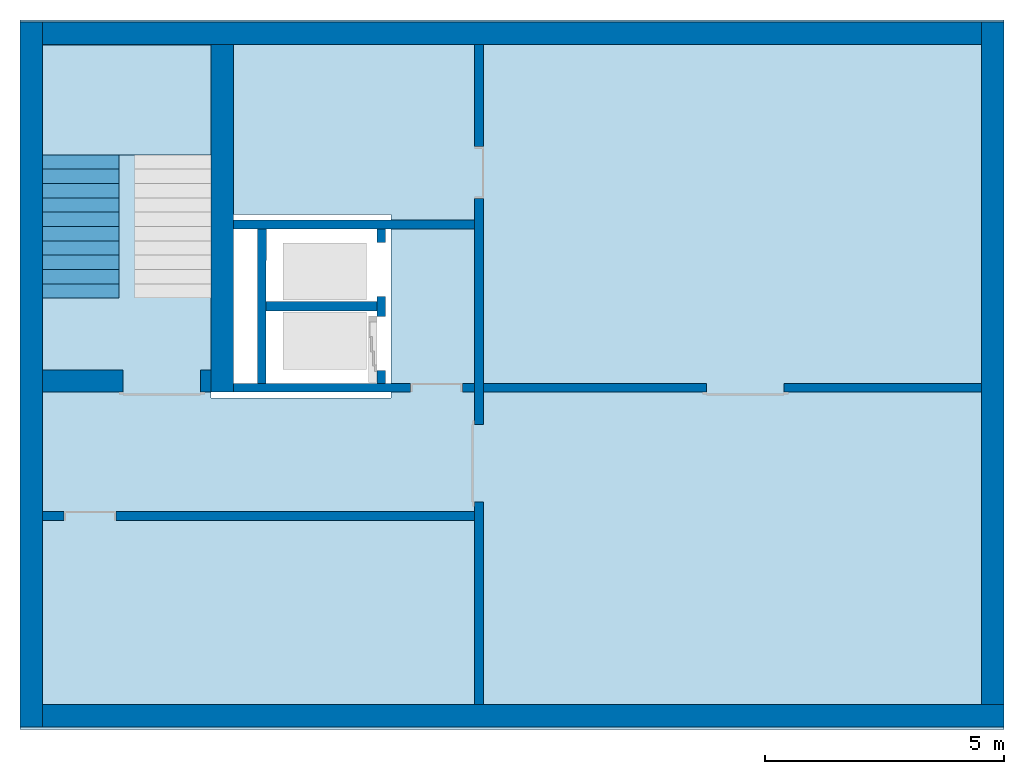
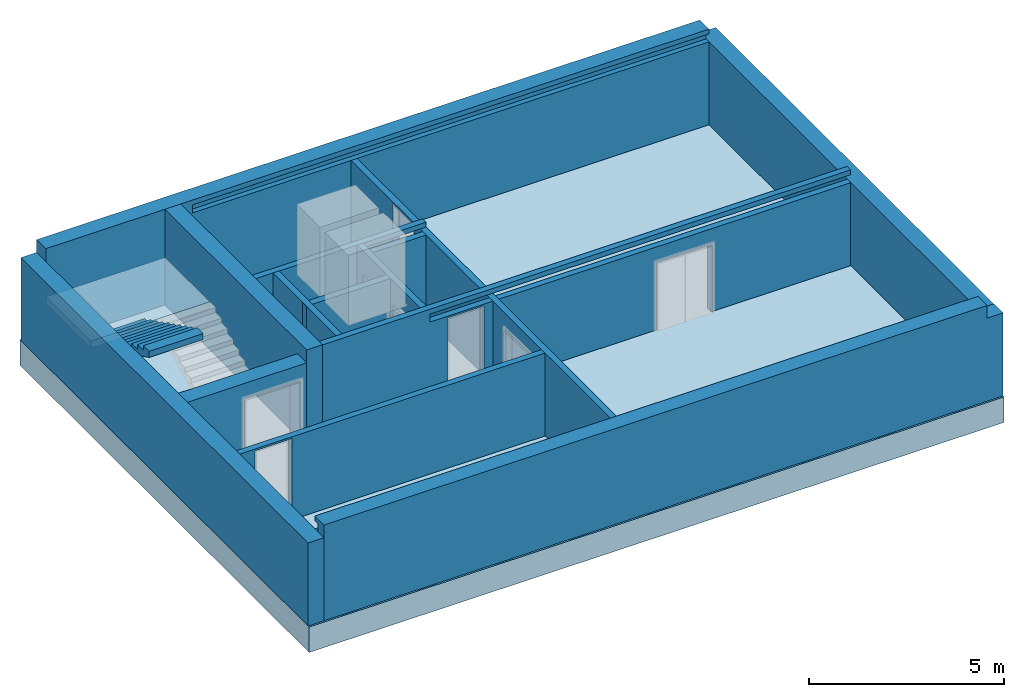
# One storey, part 1 of 5: 13 walls, 1 building element part, 1 footing, 1 slab, 8 openings, 1 element without a shape of its own.
"""IFC4 building model written with IfcOpenShell, lengths in metres."""

from ifc_helpers import new_model, entity, si_unit, converted_unit, derived_unit, direction, frame, origin_with_axes, place, context, subcontext, project, spatial, polygons, material, type_object, element, aggregate, save


model = new_model("IFC4")

# Units and contexts
model_context = context("Model", 3, precision=1e-05, world=origin_with_axes(), true_north=direction((0.0, 1.0)))
body_context = subcontext(model_context, "Body", "Model", "MODEL_VIEW")
ifc_project = project(units=[si_unit("LENGTHUNIT", "METRE"), si_unit("AREAUNIT", "SQUARE_METRE"), si_unit("VOLUMEUNIT", "CUBIC_METRE"), converted_unit("PLANEANGLEUNIT", "DEGREE", entity("IfcPlaneAngleMeasure", 0.0174532925199433), si_unit("PLANEANGLEUNIT", "RADIAN"), dimensions=[0, 0, 0, 0, 0, 0, 0]), converted_unit("TIMEUNIT", "Year", entity("IfcTimeMeasure", 31557600.0), si_unit("TIMEUNIT", "SECOND"), dimensions=[0, 0, 1, 0, 0, 0, 0]), si_unit("MASSUNIT", "GRAM", prefix="KILO"), si_unit("THERMODYNAMICTEMPERATUREUNIT", "DEGREE_CELSIUS"), si_unit("LUMINOUSINTENSITYUNIT", "LUMEN"), si_unit("ENERGYUNIT", "JOULE", prefix="MEGA"), derived_unit("THERMALCONDUCTANCEUNIT", [(si_unit("POWERUNIT", "WATT"), 1), (si_unit("LENGTHUNIT", "METRE"), -1), (si_unit("THERMODYNAMICTEMPERATUREUNIT", "KELVIN"), -1)]), derived_unit("SPECIFICHEATCAPACITYUNIT", [(si_unit("ENERGYUNIT", "JOULE"), 1), (si_unit("MASSUNIT", "GRAM", prefix="KILO"), -1), (si_unit("THERMODYNAMICTEMPERATUREUNIT", "KELVIN"), -1)]), derived_unit("MASSDENSITYUNIT", [(si_unit("MASSUNIT", "GRAM", prefix="KILO"), 1), (si_unit("VOLUMEUNIT", "CUBIC_METRE"), -1)])], contexts=[model_context])

# Site, building, storey
site_placement = place(None, origin_with_axes())
site = spatial("IfcSite", under=ifc_project, at=site_placement, CompositionType="ELEMENT")
building_placement = place(None, origin_with_axes())
building = spatial("IfcBuilding", under=site, at=building_placement, CompositionType="ELEMENT")
storey_placement = place(None, frame((0.0, 0.0, -3.0), z_axis=(0.0, 0.0, 1.0), x_axis=(1.0, 0.0, 0.0)))
storey = spatial("IfcBuildingStorey", under=building, at=storey_placement, Name="UG", CompositionType="ELEMENT", Elevation=-3.0)

# Footing
ifc_material_1 = material(Name="Stahlbeton Decke")
footing_type = type_object("IfcFootingType", Name="Stahlbeton Decke 800", PredefinedType="NOTDEFINED")
footing_placement = place(None, frame((44.584, 14.845999753475, -3.0), z_axis=(0.0, 0.0, 1.0), x_axis=(1.0, 0.0, 0.0)))
element("IfcFooting", 1, at=footing_placement, inside=storey, type_object=footing_type, material=ifc_material_1, Name="Decke-001", PredefinedType="NOTDEFINED", context=body_context, shape_type="Tessellation", body=[
    polygons([(0.0, 0.0, 0.0), (0.0, 0.0, -0.8), (-20.596, 0.0, -0.8), (-20.596, 0.0, 0.0), (0.0, -14.845999753475, 0.0), (0.0, -14.845999753475, -0.8), (-20.596, -14.845999753475, -0.8), (-12.826, -4.07099980800739, -0.8), (-16.5959999085664, -4.07099980800739, -0.8), (-16.5959999085664, -7.9109998080074, -0.8), (-12.826, -7.9109998080074, -0.8), (-20.596, -14.845999753475, 0.0), (-16.5959999085664, -7.9109998080074, 0.0), (-16.5959999085664, -4.07099980800739, 0.0), (-12.826, -4.07099980800739, 0.0), (-12.826, -7.9109998080074, 0.0)], [[[1, 2, 3, 4]], [[5, 6, 2, 1]], [[3, 2, 6, 7], [8, 9, 10, 11]], [[4, 3, 7, 12]], [[5, 1, 4, 12], [13, 14, 15, 16]], [[12, 7, 6, 5]], [[14, 9, 8, 15]], [[13, 10, 9, 14]], [[16, 11, 10, 13]], [[15, 8, 11, 16]]], closed=True),
])

# Slab
ifc_material_2 = material(Name="Stahlbeton")
slab_type = type_object("IfcSlabType", Name="Stahlbeton 220", PredefinedType="LANDING")
slab_placement = place(None, frame((24.458, 12.0249999454676, -1.5), z_axis=(0.0, 0.0, 1.0), x_axis=(1.0, 0.0, 0.0)))
element("IfcSlab", 2, at=slab_placement, inside=storey, type_object=slab_type, material=ifc_material_2, Name="Decke-002", context=body_context, shape_type="Tessellation", body=[
    polygons([(0.0, 0.0, 0.0), (0.0, 0.0, -0.22), (3.53, 0.0, -0.22), (3.53, 0.0, 0.0), (0.0, 2.30099994546756, 0.0), (0.0, 2.30099994546756, -0.22), (3.53, 2.30099994546756, -0.22), (3.53, 2.30099994546756, 0.0)], [[[1, 2, 3, 4]], [[5, 6, 2, 1]], [[3, 2, 6, 7]], [[4, 3, 7, 8]], [[5, 1, 4, 8]], [[8, 7, 6, 5]]], closed=True),
])

# Wall
wall_type_1 = type_object("IfcWallType", Name="Stahlbeton 470", PredefinedType="NOTDEFINED")
wall_1_placement = place(None, frame((24.458, 14.3318657372406, -3.0), z_axis=(0.0, 0.0, 1.0), x_axis=(0.0, -1.0, 0.0)))
element("IfcWall", 3, at=wall_1_placement, inside=storey, type_object=wall_type_1, material=ifc_material_2, Name="Wand-001", PredefinedType="NOTDEFINED", context=body_context, shape_type="Tessellation", body=[
    polygons([(14.2818657372405, -0.469999999999999, 2.6), (14.2818657372405, 0.0, 2.6), (-0.470000000000001, 0.0, 2.6), (-0.469999999999999, -0.469999999999999, 2.6), (14.2818657372405, -0.469999999999999, 0.0), (14.2818657372405, 0.0, 0.0), (-0.470000000000001, 0.0, 0.0), (-0.469999999999999, -0.469999999999999, 0.0)], [[[1, 2, 3, 4]], [[2, 1, 5, 6]], [[2, 6, 7, 3]], [[8, 4, 3, 7]], [[5, 1, 4, 8]], [[6, 5, 8, 7]]], closed=True),
])

# Wall, opening
wall_2_placement = place(None, frame((27.988, 7.05499994546755, -3.0), z_axis=(0.0, 0.0, 1.0), x_axis=(-1.0, 0.0, 0.0)))
wall_2 = element("IfcWall", 4, at=wall_2_placement, inside=storey, type_object=wall_type_1, material=ifc_material_2, Name="Wand-001", PredefinedType="NOTDEFINED", context=body_context, shape_type="Tessellation", body=[
    polygons([(1.84, -0.470000000000001, 2.11), (1.84, -0.47, 0.0), (3.53, -0.470000000000001, 0.0), (3.53, -0.47, 2.6), (0.0, -0.47, 2.6), (0.0, -0.47, 0.0), (0.219999999999999, -0.47, 0.0), (0.219999999999999, -0.470000000000001, 2.11), (1.84, 0.0, 2.11), (1.84, 0.0, 0.0), (3.53, 0.0, 0.0), (3.53, 0.0, 2.6), (0.0, 0.0, 2.6), (0.0, 0.0, 0.0), (0.219999999999999, 0.0, 0.0), (0.219999999999999, 0.0, 2.11)], [[[1, 2, 3, 4, 5, 6, 7, 8]], [[2, 1, 9, 10]], [[2, 10, 11, 3]], [[4, 3, 11, 12]], [[12, 13, 5, 4]], [[5, 13, 14, 6]], [[15, 7, 6, 14]], [[8, 7, 15, 16]], [[1, 8, 16, 9]], [[16, 15, 14, 13, 12, 11, 10, 9]]], closed=True),
])
opening_1_placement = place(None, frame((26.958, 7.05499994546755, -3.0), z_axis=(0.0, 0.0, 1.0), x_axis=(-1.0, 0.0, 0.0)))
element("IfcOpeningElement", 5, at=opening_1_placement, cuts=wall_2, context=body_context, identifier="Reference", shape_type="Tessellation", body=[
    polygons([(-0.809999999999999, -0.471, 2.11), (-0.809999999999999, -0.471, 0.0), (0.809999999999999, -0.471, 0.0), (0.809999999999999, -0.471, 2.11), (-0.809999999999999, 0.00100000000000033, 2.11), (-0.809999999999999, 0.00100000000000033, 0.0), (0.809999999999999, 0.00100000000000033, 0.0), (0.809999999999999, 0.00100000000000033, 2.11)], [[[1, 2, 3, 4]], [[5, 6, 2, 1]], [[6, 7, 3, 2]], [[7, 8, 4, 3]], [[8, 5, 1, 4]], [[7, 6, 5, 8]]], closed=True),
])

# Walls
wall_3_placement = place(None, frame((27.988, 14.3318657372406, -3.0), z_axis=(0.0, 0.0, 1.0), x_axis=(0.0, -1.0, 0.0)))
element("IfcWall", 6, at=wall_3_placement, inside=storey, type_object=wall_type_1, material=ifc_material_2, Name="Wand-003", PredefinedType="NOTDEFINED", context=body_context, shape_type="Tessellation", body=[
    polygons([(7.276865791773, 0.469999999999999, 3.0), (7.276865791773, 0.0, 3.0), (7.27686579177299, 0.0, 2.6), (7.27686579177299, 0.469999999999999, 2.6), (0.0, 0.469999999999999, 3.0), (0.0, 0.0, 3.0), (0.0, 0.0, 0.0), (7.27686579177299, 0.0, 0.0), (7.27686579177299, 0.469999999999999, 0.0), (0.0, 0.469999999999999, 0.0)], [[[1, 2, 3, 4]], [[5, 6, 2, 1]], [[6, 7, 8, 3, 2]], [[3, 8, 9, 4]], [[5, 1, 4, 9, 10]], [[6, 5, 10, 7]], [[7, 10, 9, 8]]], closed=True),
])
wall_4_placement = place(None, frame((44.114, 0.52, -3.0), z_axis=(0.0, 0.0, 1.0), x_axis=(0.0, 1.0, 0.0)))
element("IfcWall", 7, at=wall_4_placement, inside=storey, type_object=wall_type_1, material=ifc_material_2, Name="Wand-003", PredefinedType="NOTDEFINED", context=body_context, shape_type="Tessellation", body=[
    polygons([(14.2818657372405, -0.469999999999999, 2.6), (14.2818657372405, 0.0, 2.6), (0.0, 0.0, 2.6), (0.0, -0.469999999999999, 2.6), (14.2818657372405, -0.469999999999999, 0.0), (14.2818657372405, 0.0, 0.0), (0.0, 0.0, 0.0), (0.0, -0.469999999999999, 0.0)], [[[1, 2, 3, 4]], [[2, 1, 5, 6]], [[2, 6, 7, 3]], [[8, 4, 3, 7]], [[5, 1, 4, 8]], [[6, 5, 8, 7]]], closed=True),
])
wall_5_placement = place(None, frame((44.114, 14.3318657372406, -3.0), z_axis=(0.0, 0.0, 1.0), x_axis=(-1.0, 0.0, 0.0)))
element("IfcWall", 8, at=wall_5_placement, inside=storey, type_object=wall_type_1, material=ifc_material_2, Name="Wand-004", PredefinedType="NOTDEFINED", context=body_context, shape_type="Tessellation", body=[
    polygons([(0.0, 0.0, 2.85), (0.0, -0.151134016234401, 2.85), (0.0, -0.151134016234401, 2.6), (0.0, -0.470000000000001, 2.6), (0.0, -0.470000000000001, 3.0), (0.0, 0.0, 3.0), (15.306, -0.151134016234401, 2.85), (15.306, 0.0, 2.85), (15.306, -0.151134016234401, 2.6), (0.0, 0.0, 2.6), (0.0, 0.0, 0.0), (0.0, -0.470000000000001, 0.0), (19.656, -0.470000000000002, 3.0), (19.656, -0.470000000000001, 0.0), (19.656, -0.470000000000001, 2.6), (19.656, -0.470000000000002, 2.85), (19.656, 0.0, 3.0), (15.306, 0.0, 2.6), (19.656, 0.0, 2.85), (19.656, 0.0, 2.6), (19.656, 0.0, 0.0)], [[[1, 2, 3, 4, 5, 6]], [[7, 2, 1, 8]], [[9, 3, 2, 7]], [[4, 3, 10, 11, 12]], [[13, 5, 4, 12, 14, 15, 16]], [[6, 5, 13, 17]], [[18, 8, 1, 6, 17, 19, 20, 21, 11, 10]], [[7, 8, 18, 9]], [[18, 10, 3, 9]], [[21, 14, 12, 11]], [[14, 21, 20, 15]], [[19, 16, 15, 20]], [[16, 19, 17, 13]]], closed=True),
])
wall_6_placement = place(None, frame((24.458, 0.52, -3.0), z_axis=(0.0, 0.0, 1.0), x_axis=(1.0, 0.0, 0.0)))
element("IfcWall", 9, at=wall_6_placement, inside=storey, type_object=wall_type_1, material=ifc_material_2, Name="Wand-002", PredefinedType="NOTDEFINED", context=body_context, shape_type="Tessellation", body=[
    polygons([(19.656, -0.469999999999999, 2.6), (19.656, -0.156999999999999, 2.6), (19.656, -0.156999999999999, 2.85), (19.656, 0.0, 2.85), (19.656, 0.0, 3.0), (19.656, -0.469999999999999, 3.0), (20.126, 0.0, 2.6), (19.656, 0.0, 2.6), (20.126, -0.469999999999999, 2.6), (0.0, -0.156999999999999, 2.85), (0.0, -0.156999999999999, 2.6), (0.0, 0.0, 2.85), (0.0, 0.0, 3.0), (0.0, -0.47, 3.0), (0.0, -0.47, 2.6), (0.0, -0.47, 0.0), (20.126, -0.469999999999999, 0.0), (0.0, 0.0, 0.0), (0.0, 0.0, 2.6), (20.126, 0.0, 0.0)], [[[1, 2, 3, 4, 5, 6]], [[7, 8, 2, 1, 9]], [[10, 3, 2, 11]], [[10, 12, 4, 3]], [[5, 4, 12, 13]], [[5, 13, 14, 6]], [[6, 14, 15, 16, 17, 9, 1]], [[18, 19, 8, 7, 20]], [[11, 2, 8, 19]], [[9, 17, 20, 7]], [[12, 10, 11, 15, 14, 13]], [[15, 11, 19, 18, 16]], [[20, 17, 16, 18]]], closed=True),
])

# Wall, openings
wall_type_2 = type_object("IfcWallType", Name="Stahlbeton 180", PredefinedType="NOTDEFINED")
wall_7_placement = place(None, frame((31.638, 7.05499994546755, -3.0), z_axis=(0.0, 0.0, 1.0), x_axis=(0.0, 1.0, 0.0)))
wall_7 = element("IfcWall", 10, at=wall_7_placement, inside=storey, type_object=wall_type_2, material=ifc_material_2, Name="Wand-002", PredefinedType="NOTDEFINED", context=body_context, shape_type="Tessellation", body=[
    polygons([(2.0, 0.0, 0.0), (2.0, 0.0, 2.25), (3.13, 0.0, 2.25), (3.13, 0.0, 0.0), (3.42, 0.0, 0.0), (3.42, 0.0, 3.0), (0.179999999999999, 0.0, 3.0), (0.179999999999999, 0.0, 0.0), (0.450000000000002, 0.0, 0.0), (0.450000000000002, 0.0, 2.25), (1.58, 0.0, 2.25), (1.58, 0.0, 0.0), (2.0, 0.179999999999996, 0.0), (2.0, 0.179999999999996, 2.25), (3.13, 0.179999999999996, 2.25), (3.13, 0.179999999999996, 0.0), (3.42, 0.179999999999996, 0.0), (3.42, 0.179999999999996, 3.0), (0.179999999999999, 0.18, 3.0), (0.179999999999999, 0.18, 0.0), (0.450000000000002, 0.18, 0.0), (0.450000000000002, 0.18, 2.25), (1.58, 0.18, 2.25), (1.58, 0.18, 0.0)], [[[1, 2, 3, 4, 5, 6, 7, 8, 9, 10, 11, 12]], [[2, 1, 13, 14]], [[3, 2, 14, 15]], [[4, 3, 15, 16]], [[4, 16, 17, 5]], [[18, 6, 5, 17]], [[19, 7, 6, 18]], [[8, 7, 19, 20]], [[9, 8, 20, 21]], [[9, 21, 22, 10]], [[10, 22, 23, 11]], [[11, 23, 24, 12]], [[13, 1, 12, 24]], [[14, 13, 24, 23, 22, 21, 20, 19, 18, 17, 16, 15]]], closed=True),
])
opening_2_placement = place(wall_7_placement, frame((2.565, 0.0, 0.0), z_axis=(0.0, 0.0, 1.0), x_axis=(1.0, 0.0, 0.0)))
element("IfcOpeningElement", 11, at=opening_2_placement, cuts=wall_7, context=body_context, identifier="Reference", shape_type="Tessellation", body=[
    polygons([(-0.565, -0.00100000000000478, 2.25), (-0.565, -0.00100000000000478, 0.0), (0.565, -0.00100000000000478, 0.0), (0.565, -0.00100000000000478, 2.25), (-0.564999999999998, 0.181000000000001, 2.25), (-0.564999999999998, 0.181000000000001, 0.0), (0.565000000000001, 0.181000000000001, 0.0), (0.565000000000001, 0.181000000000001, 2.25)], [[[1, 2, 3, 4]], [[5, 6, 2, 1]], [[6, 7, 3, 2]], [[7, 8, 4, 3]], [[8, 5, 1, 4]], [[7, 6, 5, 8]]], closed=True),
])
opening_3_placement = place(wall_7_placement, frame((1.015, 0.0, 0.0), z_axis=(0.0, 0.0, 1.0), x_axis=(1.0, 0.0, 0.0)))
element("IfcOpeningElement", 12, at=opening_3_placement, cuts=wall_7, context=body_context, identifier="Reference", shape_type="Tessellation", body=[
    polygons([(-0.565, -0.00100000000000122, 2.25), (-0.565, -0.00100000000000122, 0.0), (0.565, -0.00100000000000122, 0.0), (0.565, -0.00100000000000122, 2.25), (-0.565, 0.181000000000004, 2.25), (-0.565, 0.181000000000004, 0.0), (0.565000000000001, 0.181000000000004, 0.0), (0.565000000000001, 0.181000000000004, 2.25)], [[[1, 2, 3, 4]], [[5, 6, 2, 1]], [[6, 7, 3, 2]], [[7, 8, 4, 3]], [[8, 5, 1, 4]], [[7, 6, 5, 8]]], closed=True),
])

# Wall, opening
wall_8_placement = place(None, frame((33.505, 4.55499994546755, -3.0), z_axis=(0.0, 0.0, 1.0), x_axis=(-1.0, 0.0, 0.0)))
wall_8 = element("IfcWall", 13, at=wall_8_placement, inside=storey, type_object=wall_type_2, material=ifc_material_2, Name="Wand-003", PredefinedType="NOTDEFINED", context=body_context, shape_type="Tessellation", body=[
    polygons([(8.59699999999999, 0.0, 2.545), (8.59699999999999, 0.0, 0.0), (9.047, 0.0, 0.0), (9.047, 0.0, 2.6), (0.0, 0.0, 2.6), (0.0, 0.0, 0.0), (7.507, 0.0, 0.0), (7.507, 0.0, 2.545), (8.59699999999999, 0.18, 2.545), (8.59699999999999, 0.18, 0.0), (9.047, 0.18, 0.0), (9.047, 0.18, 2.6), (0.0, 0.180000000000001, 2.6), (0.0, 0.18, 0.0), (7.507, 0.18, 0.0), (7.507, 0.18, 2.545)], [[[1, 2, 3, 4, 5, 6, 7, 8]], [[2, 1, 9, 10]], [[2, 10, 11, 3]], [[11, 12, 4, 3]], [[12, 13, 5, 4]], [[14, 6, 5, 13]], [[15, 7, 6, 14]], [[8, 7, 15, 16]], [[1, 8, 16, 9]], [[16, 15, 14, 13, 12, 11, 10, 9]]], closed=True),
])
opening_4_placement = place(None, frame((25.453, 4.55499994546755, -3.0), z_axis=(0.0, 0.0, 1.0), x_axis=(-1.0, 0.0, 0.0)))
element("IfcOpeningElement", 14, at=opening_4_placement, cuts=wall_8, context=body_context, identifier="Reference", shape_type="Tessellation", body=[
    polygons([(-0.544999999999998, -0.00100000000000033, 2.545), (-0.544999999999998, -0.00100000000000033, 0.0), (0.544999999999998, -0.00100000000000033, 0.0), (0.544999999999998, -0.00100000000000033, 2.545), (-0.544999999999998, 0.181, 2.545), (-0.544999999999998, 0.181, 0.0), (0.544999999999998, 0.181, 0.0), (0.544999999999998, 0.181, 2.545)], [[[1, 2, 3, 4]], [[5, 6, 2, 1]], [[6, 7, 3, 2]], [[7, 8, 4, 3]], [[8, 5, 1, 4]], [[7, 6, 5, 8]]], closed=True),
])

# Walls
wall_9_placement = place(None, frame((29.1377045594425, 7.05499994546755, -3.0), z_axis=(0.0, 0.0, 1.0), x_axis=(0.00164133421967425, 0.999998653010083, 0.0)))
element("IfcWall", 15, at=wall_9_placement, inside=storey, type_object=wall_type_2, material=ifc_material_2, Name="Wand-001", PredefinedType="NOTDEFINED", context=body_context, shape_type="Tessellation", body=[
    polygons([(0.179704801901014, 0.18, 0.0), (3.41970916615423, 0.180000000000007, 0.0), (3.42000460671172, 0.0, 0.0), (0.180000242458512, 0.0, 0.0), (0.179704801901014, 0.18, 3.0), (3.41970916615423, 0.180000000000007, 3.0), (3.42000460671172, 0.0, 3.0), (0.180000242458512, 0.0, 3.0)], [[[1, 2, 3, 4]], [[5, 6, 2, 1]], [[7, 3, 2, 6]], [[4, 3, 7, 8]], [[8, 5, 1, 4]], [[8, 7, 6, 5]]], closed=True),
])
wall_10_placement = place(None, frame((33.505, 10.6549999454676, -3.0), z_axis=(0.0, 0.0, 1.0), x_axis=(-1.0, 0.0, 0.0)))
element("IfcWall", 16, at=wall_10_placement, inside=storey, type_object=wall_type_2, material=ifc_material_2, Name="Wand-003", PredefinedType="NOTDEFINED", context=body_context, shape_type="Tessellation", body=[
    polygons([(0.0, 0.18, 3.0), (0.0, 0.180000000000001, 2.85), (0.0, 0.0, 2.85), (0.0, 0.0, 3.0), (1.8669999709129, 0.18, 2.6), (1.8669999709129, 0.18, 2.85), (5.04699999999999, 0.18, 3.0), (5.04699999999999, 0.18, 0.0), (0.0, 0.18, 0.0), (0.0, 0.180000000000003, 2.6), (1.8669999709129, -8.86263311627999e-08, 2.85), (1.8669999709129, -8.86263311627999e-08, 2.6), (0.0, 0.0, 2.6), (0.0, 0.0, 0.0), (5.04699999999999, 0.0, 0.0), (5.04699999999999, 0.0, 3.0)], [[[1, 2, 3, 4]], [[5, 6, 2, 1, 7, 8, 9, 10]], [[6, 11, 3, 2]], [[11, 12, 13, 14, 15, 16, 4, 3]], [[4, 16, 7, 1]], [[5, 12, 11, 6]], [[8, 7, 16, 15]], [[8, 15, 14, 9]], [[14, 13, 10, 9]], [[5, 10, 13, 12]]], closed=True),
])

# Wall, openings
wall_11_placement = place(None, frame((33.505, 14.3318657372406, -3.0), z_axis=(0.0, 0.0, 1.0), x_axis=(0.0, -1.0, 0.0)))
wall_11 = element("IfcWall", 17, at=wall_11_placement, inside=storey, type_object=wall_type_2, material=ifc_material_2, Name="Wand-001", PredefinedType="NOTDEFINED", context=body_context, shape_type="Tessellation", body=[
    polygons([(3.22686579177299, 0.18, 0.0), (3.22686579177299, 0.18, 2.545), (2.13686579177299, 0.18, 2.545), (2.13686579177299, 0.18, 0.0), (0.0, 0.18, 0.0), (0.0, 0.18, 2.6), (13.8118657372406, 0.18, 2.6), (13.8118657372406, 0.18, 0.0), (9.57686579177299, 0.18, 0.0), (9.57686579177299, 0.18, 2.11), (7.95686579177299, 0.18, 2.11), (7.95686579177299, 0.18, 0.0), (3.22686579177299, 0.0, 0.0), (3.22686579177299, 0.0, 2.545), (2.13686579177299, 0.0, 2.545), (2.13686579177299, 0.0, 0.0), (0.0, 0.0, 0.0), (0.0, 0.0, 2.6), (13.8118657372406, 0.0, 2.6), (13.8118657372406, 0.0, 0.0), (9.57686579177299, 0.0, 0.0), (9.57686579177299, 0.0, 2.11), (7.95686579177299, 0.0, 2.11), (7.95686579177299, 0.0, 0.0)], [[[1, 2, 3, 4, 5, 6, 7, 8, 9, 10, 11, 12]], [[2, 1, 13, 14]], [[3, 2, 14, 15]], [[4, 3, 15, 16]], [[4, 16, 17, 5]], [[17, 18, 6, 5]], [[6, 18, 19, 7]], [[7, 19, 20, 8]], [[9, 8, 20, 21]], [[9, 21, 22, 10]], [[10, 22, 23, 11]], [[11, 23, 24, 12]], [[13, 1, 12, 24]], [[14, 13, 24, 23, 22, 21, 20, 19, 18, 17, 16, 15]]], closed=True),
])
opening_5_placement = place(None, frame((33.505, 11.6499999454676, -3.0), z_axis=(0.0, 0.0, 1.0), x_axis=(0.0, -1.0, 0.0)))
element("IfcOpeningElement", 18, at=opening_5_placement, cuts=wall_11, context=body_context, identifier="Reference", shape_type="Tessellation", body=[
    polygons([(-0.545, -0.000999999999997669, 2.545), (-0.545, -0.000999999999997669, 0.0), (0.545, -0.000999999999997669, 0.0), (0.545, -0.000999999999997669, 2.545), (-0.545, 0.180999999999997, 2.545), (-0.545, 0.180999999999997, 0.0), (0.545, 0.180999999999997, 0.0), (0.545, 0.180999999999997, 2.545)], [[[1, 2, 3, 4]], [[5, 6, 2, 1]], [[6, 7, 3, 2]], [[7, 8, 4, 3]], [[8, 5, 1, 4]], [[7, 6, 5, 8]]], closed=True),
])
opening_6_placement = place(None, frame((33.505, 5.56499994546756, -3.0), z_axis=(0.0, 0.0, 1.0), x_axis=(0.0, -1.0, 0.0)))
element("IfcOpeningElement", 19, at=opening_6_placement, cuts=wall_11, context=body_context, identifier="Reference", shape_type="Tessellation", body=[
    polygons([(0.81, 0.180999999999997, 2.11), (0.81, 0.180999999999997, 0.0), (-0.81, 0.180999999999997, 0.0), (-0.81, 0.180999999999997, 2.11), (0.81, -0.000999999999997669, 2.11), (0.81, -0.000999999999997669, 0.0), (-0.81, -0.000999999999997669, 0.0), (-0.81, -0.000999999999997669, 2.11)], [[[1, 2, 3, 4]], [[5, 6, 2, 1]], [[6, 7, 3, 2]], [[7, 8, 4, 3]], [[8, 5, 1, 4]], [[7, 6, 5, 8]]], closed=True),
])

wall_12_placement = place(None, frame((27.988, 7.05499994546755, -3.0), z_axis=(0.0, 0.0, 1.0), x_axis=(1.0, 0.0, 0.0)))
wall_12 = element("IfcWall", 20, at=wall_12_placement, inside=storey, type_object=wall_type_2, material=ifc_material_2, Name="Wand-001", PredefinedType="NOTDEFINED", context=body_context, shape_type="Tessellation", body=[
    polygons([(10.370657642847, 0.18, 2.11), (10.370657642847, 0.18, 0.0), (5.69699999999999, 0.18, 0.0), (5.69699999999999, 0.180000000000002, 2.6), (8.20499999999999, 0.180000000000002, 2.6), (16.126, 0.180000000000001, 2.6), (16.126, 0.180000000000001, 0.0), (11.990657642847, 0.180000000000001, 0.0), (11.990657642847, 0.180000000000001, 2.11), (10.370657642847, 0.0, 2.11), (10.370657642847, 0.0, 0.0), (5.69699999999999, 0.0, 0.0), (5.69699999999999, 0.0, 2.6), (16.126, 0.0, 2.6), (16.126, 0.0, 0.0), (11.990657642847, 0.0, 0.0), (11.990657642847, 0.0, 2.11)], [[[1, 2, 3, 4, 5, 6, 7, 8, 9]], [[2, 1, 10, 11]], [[2, 11, 12, 3]], [[13, 4, 3, 12]], [[4, 13, 14, 6, 5]], [[6, 14, 15, 7]], [[16, 8, 7, 15]], [[9, 8, 16, 17]], [[1, 9, 17, 10]], [[17, 16, 15, 14, 13, 12, 11, 10]]], closed=True),
    polygons([(4.17199999999999, 0.18, 2.545), (4.17199999999999, 0.18, 0.0), (0.469999999999999, 0.18, 0.0), (0.469999999999999, 0.180000000000001, 3.0), (16.126, 0.180000000000001, 3.0), (16.126, 0.180000000000001, 2.85), (8.20499999999999, 0.180000000000002, 2.85), (5.69699999999999, 0.180000000000002, 2.85), (3.65000002908709, 0.18, 2.85), (3.65000002908709, 0.18, 2.6), (5.51699999999999, 0.18, 2.6), (5.51699999999999, 0.18, 0.0), (5.262, 0.18, 0.0), (5.262, 0.18, 2.545), (4.17199999999999, 1.29097926127031e-07, 2.545), (4.17199999999999, 0.0, 0.0), (0.469999999999999, 0.0, 0.0), (0.469999999999999, 0.0, 2.6), (0.469999999999999, 0.0, 3.0), (16.126, 0.0, 3.0), (16.126, 0.0, 2.85), (3.65000002908709, 1.29097926127031e-07, 2.85), (3.65000002908709, 1.29097926127031e-07, 2.6), (5.51699999999999, 0.0, 2.6), (5.51699999999999, 0.0, 0.0), (5.262, 0.0, 0.0), (5.262, 1.29097926127031e-07, 2.545)], [[[1, 2, 3, 4, 5, 6, 7, 8, 9, 10, 11, 12, 13, 14]], [[2, 1, 15, 16]], [[2, 16, 17, 3]], [[3, 17, 18, 19, 4]], [[5, 4, 19, 20]], [[21, 6, 5, 20]], [[6, 21, 22, 9, 8, 7]], [[10, 9, 22, 23]], [[24, 11, 10, 23]], [[11, 24, 25, 12]], [[26, 13, 12, 25]], [[14, 13, 26, 27]], [[1, 14, 27, 15]], [[27, 26, 25, 24, 23, 22, 21, 20, 19, 18, 17, 16, 15]]], closed=True),
])
opening_7_placement = place(None, frame((32.705, 7.05499994546755, -3.0), z_axis=(0.0, 0.0, 1.0), x_axis=(1.0, 0.0, 0.0)))
element("IfcOpeningElement", 21, at=opening_7_placement, cuts=wall_12, context=body_context, identifier="Reference", shape_type="Tessellation", body=[
    polygons([(-0.545000000000002, -0.00100000000000033, 2.545), (-0.545000000000002, -0.00100000000000033, 0.0), (0.545000000000002, -0.00100000000000033, 0.0), (0.545000000000002, -0.00100000000000033, 2.545), (-0.545000000000002, 0.181, 2.545), (-0.545000000000002, 0.181, 0.0), (0.545000000000002, 0.181, 0.0), (0.545000000000002, 0.181, 2.545)], [[[1, 2, 3, 4]], [[5, 6, 2, 1]], [[6, 7, 3, 2]], [[7, 8, 4, 3]], [[8, 5, 1, 4]], [[7, 6, 5, 8]]], closed=True),
])
opening_8_placement = place(None, frame((39.168657642847, 7.05499994546755, -3.0), z_axis=(0.0, 0.0, 1.0), x_axis=(1.0, 0.0, 0.0)))
element("IfcOpeningElement", 22, at=opening_8_placement, cuts=wall_12, context=body_context, identifier="Reference", shape_type="Tessellation", body=[
    polygons([(0.810000000000002, 0.181000000000002, 2.11), (0.810000000000002, 0.181000000000002, 0.0), (-0.810000000000002, 0.181000000000002, 0.0), (-0.810000000000002, 0.181000000000003, 2.11), (0.810000000000002, -0.00100000000000478, 2.11), (0.810000000000002, -0.00100000000000478, 0.0), (-0.810000000000002, -0.00100000000000478, 0.0), (-0.810000000000002, -0.00100000000000389, 2.11)], [[[1, 2, 3, 4]], [[5, 6, 2, 1]], [[6, 7, 3, 2]], [[7, 8, 4, 3]], [[8, 5, 1, 4]], [[7, 6, 5, 8]]], closed=True),
])

# Wall
wall_type_3 = type_object("IfcWallType", Name="Stahlbeton 200", PredefinedType="NOTDEFINED")
wall_13_placement = place(None, frame((28.958, 8.85499994546755, -3.0), z_axis=(0.0, 0.0, 1.0), x_axis=(1.0, 0.0, 0.0)))
element("IfcWall", 23, at=wall_13_placement, inside=storey, type_object=wall_type_3, material=ifc_material_2, Name="Wand-001", PredefinedType="NOTDEFINED", context=body_context, shape_type="Tessellation", body=[
    polygons([(0.00282285620201961, 0.0999999999999996, 0.0), (0.00249458891590848, -0.0999999999999996, 0.0), (0.0, -0.0999999999999996, 0.0), (0.0, 0.0999999999999996, 0.0), (0.00282285620201961, 0.0999999999999996, 3.0), (0.00249458891590848, -0.0999999999999996, 3.0), (0.0, -0.0999999999999996, 3.0), (0.0, 0.0999999999999996, 3.0)], [[[1, 2, 3, 4]], [[2, 1, 5, 6]], [[2, 6, 7, 3]], [[8, 4, 3, 7]], [[5, 1, 4, 8]], [[6, 5, 8, 7]]], closed=True),
    polygons([(2.5, 0.0999999999999996, 0.0), (2.5, -0.0999999999999996, 0.0), (0.18249483137442, -0.0999999999999996, 0.0), (0.182823098660531, 0.0999999999999996, 0.0), (2.5, 0.0999999999999996, 3.0), (2.5, -0.0999999999999996, 3.0), (0.18249483137442, -0.0999999999999996, 3.0), (0.182823098660531, 0.0999999999999996, 3.0)], [[[1, 2, 3, 4]], [[2, 1, 5, 6]], [[2, 6, 7, 3]], [[8, 4, 3, 7]], [[5, 1, 4, 8]], [[6, 5, 8, 7]]], closed=True),
])

# Stair, building element part
stair_type = type_object("IfcStairType", PredefinedType="NOTDEFINED")
stair_placement = place(None, frame((24.458, 12.0249999454676, -1.5), z_axis=(0.0, 0.0, 1.0), x_axis=(1.0, 0.0, 0.0)))
stair = element("IfcStair", 24, at=stair_placement, inside=storey, type_object=stair_type, Name="Treppe - 003", PredefinedType="NOTDEFINED")
building_element_part_placement = place(None, frame((24.458, 12.0249999454676, -1.5), z_axis=(0.0, 0.0, 1.0), x_axis=(1.0, 0.0, 0.0)))
building_element_part = element("IfcBuildingElementPart", 25, at=building_element_part_placement, material=ifc_material_1, Name="Stahlbeton Decke", PredefinedType="NOTDEFINED", context=body_context, shape_type="Tessellation", body=[
    polygons([(1.6, 0.0, 0.15), (1.6, 0.0, -0.190065778087482), (0.0, 0.0, -0.190065778087482), (0.0, 0.0, 0.15), (1.6, 0.0, -0.22), (1.6, -0.299999999999999, 0.15), (1.6, -0.299999999999999, 0.3), (1.6, -0.6, 0.3), (1.6, -0.6, 0.45), (1.6, -0.899999999999999, 0.45), (1.6, -0.899999999999999, 0.6), (1.6, -1.2, 0.6), (1.6, -1.2, 0.75), (1.6, -1.5, 0.75), (1.6, -1.5, 0.9), (1.6, -1.8, 0.9), (1.6, -1.8, 1.05), (1.6, -2.1, 1.05), (1.6, -2.1, 1.2), (1.6, -2.4, 1.2), (1.6, -2.4, 1.35), (1.6, -2.7, 1.35), (1.6, -2.7, 1.5), (1.6, -3.0, 1.5), (1.6, -3.0, 1.30993422191252), (1.6, -2.925, 1.27243422191252), (1.6, -2.85, 1.23493422191252), (1.6, -2.775, 1.19743422191252), (1.6, -2.7, 1.15993422191252), (1.6, -2.6, 1.10993422191252), (1.6, -2.5, 1.05993422191252), (1.6, -2.4, 1.00993422191252), (1.6, -2.3, 0.959934221912518), (1.6, -2.2, 0.909934221912518), (1.6, -2.1, 0.859934221912518), (1.6, -2.0, 0.809934221912518), (1.6, -1.9, 0.759934221912518), (1.6, -1.8, 0.709934221912518), (1.6, -1.725, 0.672434221912518), (1.6, -1.65, 0.634934221912518), (1.6, -1.575, 0.597434221912518), (1.6, -1.5, 0.559934221912518), (1.6, -1.425, 0.522434221912518), (1.6, -1.35, 0.484934221912518), (1.6, -1.275, 0.447434221912518), (1.6, -1.2, 0.409934221912518), (1.6, -1.125, 0.372434221912518), (1.6, -1.05, 0.334934221912518), (1.6, -0.975, 0.297434221912518), (1.6, -0.899999999999999, 0.259934221912518), (1.6, -0.799999999999999, 0.209934221912518), (1.6, -0.699999999999999, 0.159934221912518), (1.6, -0.6, 0.109934221912518), (1.6, -0.5, 0.0599342219125178), (1.6, -0.4, 0.0099342219125178), (1.6, -0.299999999999999, -0.0400657780874822), (1.6, -0.25, -0.0650657780874822), (1.6, -0.25, -0.22), (0.0, 0.0, -0.22), (0.0, -0.25, -0.22), (0.0, -0.25, -0.0650657780874822), (0.0, -0.299999999999999, -0.0400657780874822), (0.0, -0.4, 0.0099342219125178), (0.0, -0.5, 0.0599342219125178), (0.0, -0.6, 0.109934221912518), (0.0, -0.699999999999999, 0.159934221912518), (0.0, -0.799999999999999, 0.209934221912518), (0.0, -0.899999999999999, 0.259934221912518), (0.0, -0.975, 0.297434221912518), (0.0, -1.05, 0.334934221912518), (0.0, -1.125, 0.372434221912518), (0.0, -1.2, 0.409934221912518), (0.0, -1.275, 0.447434221912518), (0.0, -1.35, 0.484934221912518), (0.0, -1.425, 0.522434221912518), (0.0, -1.5, 0.559934221912518), (0.0, -1.575, 0.597434221912518), (0.0, -1.65, 0.634934221912518), (0.0, -1.725, 0.672434221912518), (0.0, -1.8, 0.709934221912518), (0.0, -1.9, 0.759934221912518), (0.0, -2.0, 0.809934221912518), (0.0, -2.1, 0.859934221912518), (0.0, -2.2, 0.909934221912518), (0.0, -2.3, 0.959934221912518), (0.0, -2.4, 1.00993422191252), (0.0, -2.5, 1.05993422191252), (0.0, -2.6, 1.10993422191252), (0.0, -2.7, 1.15993422191252), (0.0, -2.775, 1.19743422191252), (0.0, -2.85, 1.23493422191252), (0.0, -2.925, 1.27243422191252), (0.0, -3.0, 1.30993422191252), (0.0, -3.0, 1.5), (0.0, -2.7, 1.5), (0.0, -2.7, 1.35), (0.0, -2.4, 1.35), (0.0, -2.4, 1.2), (0.0, -2.1, 1.2), (0.0, -2.1, 1.05), (0.0, -1.8, 1.05), (0.0, -1.8, 0.9), (0.0, -1.5, 0.9), (0.0, -1.5, 0.75), (0.0, -1.2, 0.75), (0.0, -1.2, 0.6), (0.0, -0.899999999999999, 0.6), (0.0, -0.899999999999999, 0.45), (0.0, -0.6, 0.45), (0.0, -0.6, 0.3), (0.0, -0.299999999999999, 0.3), (0.0, -0.299999999999999, 0.15)], [[[1, 2, 3, 4]], [[5, 2, 1, 6, 7, 8, 9, 10, 11, 12, 13, 14, 15, 16, 17, 18, 19, 20, 21, 22, 23, 24, 25, 26, 27, 28, 29, 30, 31, 32, 33, 34, 35, 36, 37, 38, 39, 40, 41, 42, 43, 44, 45, 46, 47, 48, 49, 50, 51, 52, 53, 54, 55, 56, 57, 58]], [[59, 3, 2, 5]], [[60, 61, 62, 63, 64, 65, 66, 67, 68, 69, 70, 71, 72, 73, 74, 75, 76, 77, 78, 79, 80, 81, 82, 83, 84, 85, 86, 87, 88, 89, 90, 91, 92, 93, 94, 95, 96, 97, 98, 99, 100, 101, 102, 103, 104, 105, 106, 107, 108, 109, 110, 111, 112, 4, 3, 59]], [[6, 1, 4, 112]], [[112, 111, 7, 6]], [[8, 7, 111, 110]], [[110, 109, 9, 8]], [[10, 9, 109, 108]], [[108, 107, 11, 10]], [[12, 11, 107, 106]], [[106, 105, 13, 12]], [[14, 13, 105, 104]], [[104, 103, 15, 14]], [[16, 15, 103, 102]], [[102, 101, 17, 16]], [[18, 17, 101, 100]], [[100, 99, 19, 18]], [[20, 19, 99, 98]], [[98, 97, 21, 20]], [[22, 21, 97, 96]], [[96, 95, 23, 22]], [[95, 94, 24, 23]], [[24, 94, 93, 25]], [[26, 25, 93, 92]], [[27, 26, 92, 91]], [[28, 27, 91, 90]], [[29, 28, 90, 89]], [[30, 29, 89, 88]], [[31, 30, 88, 87]], [[32, 31, 87, 86]], [[33, 32, 86, 85]], [[34, 33, 85, 84]], [[35, 34, 84, 83]], [[36, 35, 83, 82]], [[37, 36, 82, 81]], [[38, 37, 81, 80]], [[39, 38, 80, 79]], [[40, 39, 79, 78]], [[41, 40, 78, 77]], [[42, 41, 77, 76]], [[43, 42, 76, 75]], [[44, 43, 75, 74]], [[45, 44, 74, 73]], [[46, 45, 73, 72]], [[47, 46, 72, 71]], [[48, 47, 71, 70]], [[49, 48, 70, 69]], [[50, 49, 69, 68]], [[51, 50, 68, 67]], [[52, 51, 67, 66]], [[53, 52, 66, 65]], [[54, 53, 65, 64]], [[55, 54, 64, 63]], [[56, 55, 63, 62]], [[62, 61, 57, 56]], [[58, 57, 61, 60]], [[58, 60, 59, 5]]], closed=True),
])
aggregate(stair, [building_element_part])

save(model, "model.ifc")
